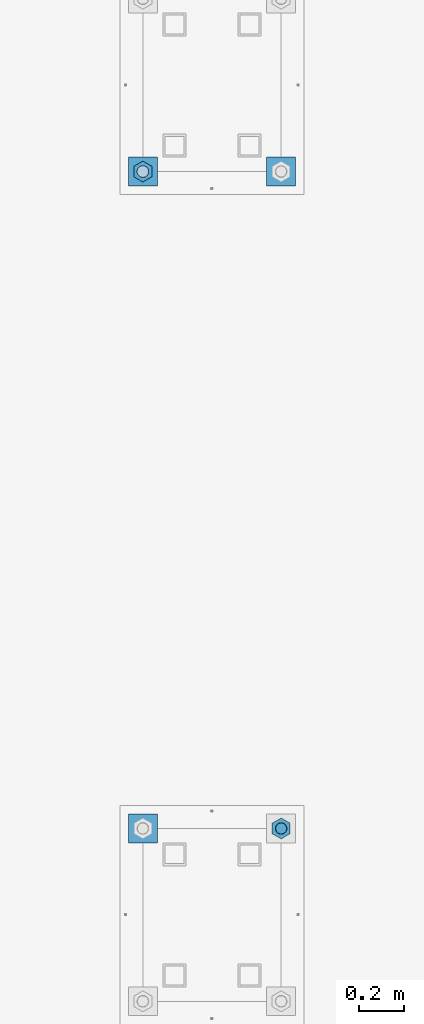
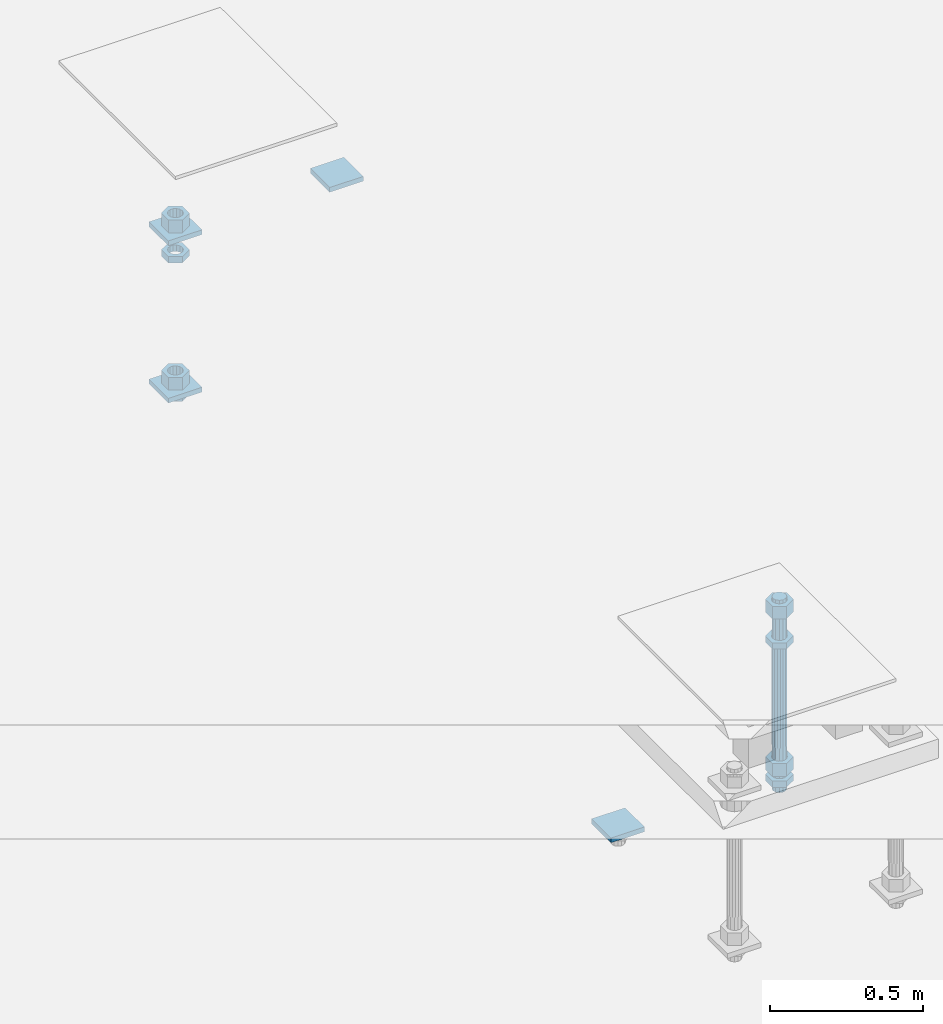
# One storey, part 2725 of 3843: 13 beams, 2 elements without a shape of their own.
"""IFC2X3 building model written with IfcOpenShell, lengths in millimetres."""

from ifc_helpers import new_model, si_unit, frame, origin_with_axes, place, context, subcontext, project, spatial, faceted_brep, material, type_object, element, aggregate, save


model = new_model("IFC2X3")

# Units and contexts
model_context = context("Model", 3, precision=1e-05, world=origin_with_axes())
body_context = subcontext(model_context, "Body", "Model", "MODEL_VIEW")
ifc_project = project(units=[si_unit("LENGTHUNIT", "METRE", prefix="MILLI"), si_unit("AREAUNIT", "SQUARE_METRE"), si_unit("VOLUMEUNIT", "CUBIC_METRE"), si_unit("MASSUNIT", "GRAM", prefix="KILO"), si_unit("TIMEUNIT", "SECOND"), si_unit("PLANEANGLEUNIT", "RADIAN"), si_unit("SOLIDANGLEUNIT", "STERADIAN"), si_unit("THERMODYNAMICTEMPERATUREUNIT", "DEGREE_CELSIUS"), si_unit("LUMINOUSINTENSITYUNIT", "LUMEN")], contexts=[model_context])

# Site, building, storey
site_placement = place(None, origin_with_axes())
site = spatial("IfcSite", under=ifc_project, at=site_placement, CompositionType="ELEMENT")
building_placement = place(site_placement, origin_with_axes())
building = spatial("IfcBuilding", under=site, at=building_placement, Name="Undefined", CompositionType="ELEMENT")
storey_placement = place(building_placement, origin_with_axes())
storey = spatial("IfcBuildingStorey", under=building, at=storey_placement, Name="Undefined", CompositionType="ELEMENT", Elevation=0.0)

# Assembly, beams
assembly_1_placement = place(storey_placement, origin_with_axes())
assembly_1 = element("IfcElementAssembly", 1, at=assembly_1_placement, inside=storey, Name="TEMPLATE", AssemblyPlace="NOTDEFINED", PredefinedType="RIGID_FRAME")
ifc_material_1 = material(Name="STEEL/A36")
beam_type_1 = type_object("IfcBeamType", PredefinedType="NOTDEFINED")
beam_1_placement = place(assembly_1_placement, frame((115862.099998474, 35737.8, 29873.575), z_axis=(0.0, 1.0, 0.0), x_axis=(-1.0, 0.0, 0.0)))
beam_1 = element("IfcBeam", 2, at=beam_1_placement, type_object=beam_type_1, material=ifc_material_1, Name="WASHER_PLATE", context=body_context, shape_type="Brep", body=[
    faceted_brep([(0.0, 9.52500000000146, -63.5), (0.0, 9.52500000000146, 63.5), (127.0, 9.52500000000146, 63.5), (127.0, 9.52500000000146, -63.5), (0.0, -9.52500000000146, 63.5), (127.0, -9.52500000000146, 63.5), (0.0, -9.52500000000146, -63.5), (127.0, -9.52500000000146, -63.5)], [[[0, 1, 2, 3]], [[1, 4, 5, 2]], [[4, 6, 7, 5]], [[6, 0, 3, 7]], [[5, 7, 3, 2]], [[6, 4, 1, 0]]]),
])
beam_2_placement = place(assembly_1_placement, frame((116471.7, 35737.8, 29873.575), z_axis=(0.0, 1.0, 0.0), x_axis=(-1.0, 0.0, 0.0)))
beam_2 = element("IfcBeam", 3, at=beam_2_placement, type_object=beam_type_1, material=ifc_material_1, Name="WASHER_PLATE", context=body_context, shape_type="Brep", body=[
    faceted_brep([(0.0, 9.52500000000146, -63.5), (0.0, 9.52500000000146, 63.5), (127.0, 9.52500000000146, 63.5), (127.0, 9.52500000000146, -63.5), (0.0, -9.52500000000146, 63.5), (127.0, -9.52500000000146, 63.5), (0.0, -9.52500000000146, -63.5), (127.0, -9.52500000000146, -63.5)], [[[0, 1, 2, 3]], [[1, 4, 5, 2]], [[4, 6, 7, 5]], [[6, 0, 3, 7]], [[5, 7, 3, 2]], [[6, 4, 1, 0]]]),
])
beam_3_placement = place(assembly_1_placement, frame((115862.099998474, 35737.8, 29244.925), z_axis=(0.0, 1.0, 0.0), x_axis=(-1.0, 0.0, 0.0)))
beam_3 = element("IfcBeam", 4, at=beam_3_placement, type_object=beam_type_1, material=ifc_material_1, Name="WASHER_PLATE", context=body_context, shape_type="Brep", body=[
    faceted_brep([(0.0, 9.52500000000146, -63.5), (0.0, 9.52500000000146, 63.5), (127.0, 9.52500000000146, 63.5), (127.0, 9.52500000000146, -63.5), (0.0, -9.52500000000146, 63.5), (127.0, -9.52500000000146, 63.5), (0.0, -9.52500000000146, -63.5), (127.0, -9.52500000000146, -63.5)], [[[0, 1, 2, 3]], [[1, 4, 5, 2]], [[4, 6, 7, 5]], [[6, 0, 3, 7]], [[5, 7, 3, 2]], [[6, 4, 1, 0]]]),
])

# Assembly, beam
assembly_2_placement = place(storey_placement, origin_with_axes())
assembly_2 = element("IfcElementAssembly", 5, at=assembly_2_placement, inside=storey, Name="TEMPLATE", AssemblyPlace="NOTDEFINED", PredefinedType="RIGID_FRAME")
beam_4_placement = place(assembly_2_placement, frame((115862.099998474, 32842.2, 29244.925), z_axis=(0.0, 1.0, 0.0), x_axis=(-1.0, 0.0, 0.0)))
beam_4 = element("IfcBeam", 6, at=beam_4_placement, type_object=beam_type_1, material=ifc_material_1, Name="WASHER_PLATE", context=body_context, shape_type="Brep", body=[
    faceted_brep([(0.0, 9.52500000000146, -63.5), (0.0, 9.52500000000146, 63.5), (127.0, 9.52500000000146, 63.5), (127.0, 9.52500000000146, -63.5), (0.0, -9.52500000000146, 63.5), (127.0, -9.52500000000146, 63.5), (0.0, -9.52500000000146, -63.5), (127.0, -9.52500000000146, -63.5)], [[[0, 1, 2, 3]], [[1, 4, 5, 2]], [[4, 6, 7, 5]], [[6, 0, 3, 7]], [[5, 7, 3, 2]], [[6, 4, 1, 0]]]),
])

# Beam
beam_type_2 = type_object("IfcBeamType", Name="2_HALF_NUT", PredefinedType="NOTDEFINED")
beam_5_placement = place(assembly_1_placement, frame((115798.599998474, 35737.8, 29787.85), z_axis=(-1.0, 0.0, 0.0), x_axis=(0.0, 0.0, -1.0)))
beam_5 = element("IfcBeam", 7, at=beam_5_placement, type_object=beam_type_2, material=ifc_material_1, Name="NUT", ObjectType="2_HALF_NUT", context=body_context, shape_type="Brep", body=[
    faceted_brep([(0.0, -46.0369987487793, 0.0), (0.0, -23.0184993743896, -39.869213104248), (25.4000000000015, -23.0184993743896, -39.869213104248), (25.4000000000015, -46.0369987487793, 0.0), (0.0, 23.0184993743896, -39.869213104248), (25.4000000000015, 23.0184993743896, -39.869213104248), (0.0, 46.0369987487793, 0.0), (25.4000000000015, 46.0369987487793, 0.0), (0.0, 23.0184993743896, 39.869213104248), (25.4000000000015, 23.0184993743896, 39.869213104248), (0.0, -23.0184993743896, 39.869213104248), (25.4000000000015, -23.0184993743896, 39.869213104248), (0.0, 0.0, 26.1940002441406), (0.0, 11.3650617044477, 23.5999013092805), (25.4000000000015, 11.3650617044477, 23.5999013092805), (25.4000000000015, 0.0, 26.1940002441406), (0.0, 20.4791109456419, 16.3316083006721), (25.4000000000015, 20.4791109456419, 16.3316083006721), (0.0, 25.5370200498292, 5.82867859874386), (25.4000000000015, 25.5370200498292, 5.82867859874386), (0.0, 25.5370200498292, -5.82867859874386), (25.4000000000015, 25.5370200498292, -5.82867859874386), (0.0, 20.4791109456419, -16.3316083006721), (25.4000000000015, 20.4791109456419, -16.3316083006721), (0.0, 11.3650617044477, -23.5999013092805), (25.4000000000015, 11.3650617044477, -23.5999013092805), (0.0, 0.0, -26.1940002441406), (25.4000000000015, 0.0, -26.1940002441406), (0.0, -11.3650617044477, -23.5999013092805), (25.4000000000015, -11.3650617044477, -23.5999013092805), (0.0, -20.4791109456419, -16.3316083006721), (25.4000000000015, -20.4791109456419, -16.3316083006721), (0.0, -25.5370200498292, -5.82867859874386), (25.4000000000015, -25.5370200498292, -5.82867859874386), (0.0, -25.5370200498292, 5.82867859874386), (25.4000000000015, -25.5370200498292, 5.82867859874386), (0.0, -20.4791109456419, 16.3316083006721), (25.4000000000015, -20.4791109456419, 16.3316083006721), (0.0, -11.3650617044477, 23.5999013092805), (25.4000000000015, -11.3650617044477, 23.5999013092805)], [[[0, 1, 2, 3]], [[1, 4, 5, 2]], [[4, 6, 7, 5]], [[6, 8, 9, 7]], [[8, 10, 11, 9]], [[10, 0, 3, 11]], [[12, 13, 14, 15]], [[13, 16, 17, 14]], [[16, 18, 19, 17]], [[18, 20, 21, 19]], [[20, 22, 23, 21]], [[22, 24, 25, 23]], [[24, 26, 27, 25]], [[26, 28, 29, 27]], [[28, 30, 31, 29]], [[30, 32, 33, 31]], [[32, 34, 35, 33]], [[34, 36, 37, 35]], [[36, 38, 39, 37]], [[38, 12, 15, 39]], [[5, 7, 9, 11, 3, 2], [17, 19, 21, 23, 25, 27, 29, 31, 33, 35, 37, 39, 15, 14]], [[10, 8, 6, 4, 1, 0], [38, 36, 34, 32, 30, 28, 26, 24, 22, 20, 18, 16, 13, 12]]]),
])

beam_6_placement = place(assembly_1_placement, frame((115798.599998474, 35737.8, 29235.4), z_axis=(-1.0, 0.0, 0.0), x_axis=(0.0, 0.0, -1.0)))
beam_6 = element("IfcBeam", 8, at=beam_6_placement, type_object=beam_type_2, material=ifc_material_1, Name="NUT", ObjectType="2_HALF_NUT", context=body_context, shape_type="Brep", body=[
    faceted_brep([(0.0, -46.0369987487793, 0.0), (0.0, -23.0184993743896, -39.869213104248), (25.4000000000015, -23.0184993743896, -39.869213104248), (25.4000000000015, -46.0369987487793, 0.0), (0.0, 23.0184993743896, -39.869213104248), (25.4000000000015, 23.0184993743896, -39.869213104248), (0.0, 46.0369987487793, 0.0), (25.4000000000015, 46.0369987487793, 0.0), (0.0, 23.0184993743896, 39.869213104248), (25.4000000000015, 23.0184993743896, 39.869213104248), (0.0, -23.0184993743896, 39.869213104248), (25.4000000000015, -23.0184993743896, 39.869213104248), (0.0, 0.0, 26.1940002441406), (0.0, 11.3650617044477, 23.5999013092805), (25.4000000000015, 11.3650617044477, 23.5999013092805), (25.4000000000015, 0.0, 26.1940002441406), (0.0, 20.4791109456419, 16.3316083006721), (25.4000000000015, 20.4791109456419, 16.3316083006721), (0.0, 25.5370200498292, 5.82867859874386), (25.4000000000015, 25.5370200498292, 5.82867859874386), (0.0, 25.5370200498292, -5.82867859874386), (25.4000000000015, 25.5370200498292, -5.82867859874386), (0.0, 20.4791109456419, -16.3316083006721), (25.4000000000015, 20.4791109456419, -16.3316083006721), (0.0, 11.3650617044477, -23.5999013092805), (25.4000000000015, 11.3650617044477, -23.5999013092805), (0.0, 0.0, -26.1940002441406), (25.4000000000015, 0.0, -26.1940002441406), (0.0, -11.3650617044477, -23.5999013092805), (25.4000000000015, -11.3650617044477, -23.5999013092805), (0.0, -20.4791109456419, -16.3316083006721), (25.4000000000015, -20.4791109456419, -16.3316083006721), (0.0, -25.5370200498292, -5.82867859874386), (25.4000000000015, -25.5370200498292, -5.82867859874386), (0.0, -25.5370200498292, 5.82867859874386), (25.4000000000015, -25.5370200498292, 5.82867859874386), (0.0, -20.4791109456419, 16.3316083006721), (25.4000000000015, -20.4791109456419, 16.3316083006721), (0.0, -11.3650617044477, 23.5999013092805), (25.4000000000015, -11.3650617044477, 23.5999013092805)], [[[0, 1, 2, 3]], [[1, 4, 5, 2]], [[4, 6, 7, 5]], [[6, 8, 9, 7]], [[8, 10, 11, 9]], [[10, 0, 3, 11]], [[12, 13, 14, 15]], [[13, 16, 17, 14]], [[16, 18, 19, 17]], [[18, 20, 21, 19]], [[20, 22, 23, 21]], [[22, 24, 25, 23]], [[24, 26, 27, 25]], [[26, 28, 29, 27]], [[28, 30, 31, 29]], [[30, 32, 33, 31]], [[32, 34, 35, 33]], [[34, 36, 37, 35]], [[36, 38, 39, 37]], [[38, 12, 15, 39]], [[5, 7, 9, 11, 3, 2], [17, 19, 21, 23, 25, 27, 29, 31, 33, 35, 37, 39, 15, 14]], [[10, 8, 6, 4, 1, 0], [38, 36, 34, 32, 30, 28, 26, 24, 22, 20, 18, 16, 13, 12]]]),
])

beam_7_placement = place(assembly_2_placement, frame((116408.2, 32842.2, 29787.85), z_axis=(-1.0, 0.0, 0.0), x_axis=(0.0, 0.0, -1.0)))
beam_7 = element("IfcBeam", 9, at=beam_7_placement, type_object=beam_type_2, material=ifc_material_1, Name="NUT", ObjectType="2_HALF_NUT", context=body_context, shape_type="Brep", body=[
    faceted_brep([(0.0, -46.0369987487793, 0.0), (0.0, -23.0184993743896, -39.869213104248), (25.4000000000015, -23.0184993743896, -39.869213104248), (25.4000000000015, -46.0369987487793, 0.0), (0.0, 23.0184993743896, -39.869213104248), (25.4000000000015, 23.0184993743896, -39.869213104248), (0.0, 46.0369987487793, 0.0), (25.4000000000015, 46.0369987487793, 0.0), (0.0, 23.0184993743896, 39.869213104248), (25.4000000000015, 23.0184993743896, 39.869213104248), (0.0, -23.0184993743896, 39.869213104248), (25.4000000000015, -23.0184993743896, 39.869213104248), (0.0, 0.0, 26.1940002441406), (0.0, 11.3650617044477, 23.5999013092805), (25.4000000000015, 11.3650617044477, 23.5999013092805), (25.4000000000015, 0.0, 26.1940002441406), (0.0, 20.4791109456419, 16.3316083006721), (25.4000000000015, 20.4791109456419, 16.3316083006721), (0.0, 25.5370200498292, 5.82867859874386), (25.4000000000015, 25.5370200498292, 5.82867859874386), (0.0, 25.5370200498292, -5.82867859874386), (25.4000000000015, 25.5370200498292, -5.82867859874386), (0.0, 20.4791109456419, -16.3316083006721), (25.4000000000015, 20.4791109456419, -16.3316083006721), (0.0, 11.3650617044477, -23.5999013092805), (25.4000000000015, 11.3650617044477, -23.5999013092805), (0.0, 0.0, -26.1940002441406), (25.4000000000015, 0.0, -26.1940002441406), (0.0, -11.3650617044477, -23.5999013092805), (25.4000000000015, -11.3650617044477, -23.5999013092805), (0.0, -20.4791109456419, -16.3316083006721), (25.4000000000015, -20.4791109456419, -16.3316083006721), (0.0, -25.5370200498292, -5.82867859874386), (25.4000000000015, -25.5370200498292, -5.82867859874386), (0.0, -25.5370200498292, 5.82867859874386), (25.4000000000015, -25.5370200498292, 5.82867859874386), (0.0, -20.4791109456419, 16.3316083006721), (25.4000000000015, -20.4791109456419, 16.3316083006721), (0.0, -11.3650617044477, 23.5999013092805), (25.4000000000015, -11.3650617044477, 23.5999013092805)], [[[0, 1, 2, 3]], [[1, 4, 5, 2]], [[4, 6, 7, 5]], [[6, 8, 9, 7]], [[8, 10, 11, 9]], [[10, 0, 3, 11]], [[12, 13, 14, 15]], [[13, 16, 17, 14]], [[16, 18, 19, 17]], [[18, 20, 21, 19]], [[20, 22, 23, 21]], [[22, 24, 25, 23]], [[24, 26, 27, 25]], [[26, 28, 29, 27]], [[28, 30, 31, 29]], [[30, 32, 33, 31]], [[32, 34, 35, 33]], [[34, 36, 37, 35]], [[36, 38, 39, 37]], [[38, 12, 15, 39]], [[5, 7, 9, 11, 3, 2], [17, 19, 21, 23, 25, 27, 29, 31, 33, 35, 37, 39, 15, 14]], [[10, 8, 6, 4, 1, 0], [38, 36, 34, 32, 30, 28, 26, 24, 22, 20, 18, 16, 13, 12]]]),
])

beam_8_placement = place(assembly_2_placement, frame((116408.2, 32842.2, 29235.4), z_axis=(-1.0, 0.0, 0.0), x_axis=(0.0, 0.0, -1.0)))
beam_8 = element("IfcBeam", 10, at=beam_8_placement, type_object=beam_type_2, material=ifc_material_1, Name="NUT", ObjectType="2_HALF_NUT", context=body_context, shape_type="Brep", body=[
    faceted_brep([(0.0, -46.0369987487793, 0.0), (0.0, -23.0184993743896, -39.869213104248), (25.4000000000015, -23.0184993743896, -39.869213104248), (25.4000000000015, -46.0369987487793, 0.0), (0.0, 23.0184993743896, -39.869213104248), (25.4000000000015, 23.0184993743896, -39.869213104248), (0.0, 46.0369987487793, 0.0), (25.4000000000015, 46.0369987487793, 0.0), (0.0, 23.0184993743896, 39.869213104248), (25.4000000000015, 23.0184993743896, 39.869213104248), (0.0, -23.0184993743896, 39.869213104248), (25.4000000000015, -23.0184993743896, 39.869213104248), (0.0, 0.0, 26.1940002441406), (0.0, 11.3650617044477, 23.5999013092805), (25.4000000000015, 11.3650617044477, 23.5999013092805), (25.4000000000015, 0.0, 26.1940002441406), (0.0, 20.4791109456419, 16.3316083006721), (25.4000000000015, 20.4791109456419, 16.3316083006721), (0.0, 25.5370200498292, 5.82867859874386), (25.4000000000015, 25.5370200498292, 5.82867859874386), (0.0, 25.5370200498292, -5.82867859874386), (25.4000000000015, 25.5370200498292, -5.82867859874386), (0.0, 20.4791109456419, -16.3316083006721), (25.4000000000015, 20.4791109456419, -16.3316083006721), (0.0, 11.3650617044477, -23.5999013092805), (25.4000000000015, 11.3650617044477, -23.5999013092805), (0.0, 0.0, -26.1940002441406), (25.4000000000015, 0.0, -26.1940002441406), (0.0, -11.3650617044477, -23.5999013092805), (25.4000000000015, -11.3650617044477, -23.5999013092805), (0.0, -20.4791109456419, -16.3316083006721), (25.4000000000015, -20.4791109456419, -16.3316083006721), (0.0, -25.5370200498292, -5.82867859874386), (25.4000000000015, -25.5370200498292, -5.82867859874386), (0.0, -25.5370200498292, 5.82867859874386), (25.4000000000015, -25.5370200498292, 5.82867859874386), (0.0, -20.4791109456419, 16.3316083006721), (25.4000000000015, -20.4791109456419, 16.3316083006721), (0.0, -11.3650617044477, 23.5999013092805), (25.4000000000015, -11.3650617044477, 23.5999013092805)], [[[0, 1, 2, 3]], [[1, 4, 5, 2]], [[4, 6, 7, 5]], [[6, 8, 9, 7]], [[8, 10, 11, 9]], [[10, 0, 3, 11]], [[12, 13, 14, 15]], [[13, 16, 17, 14]], [[16, 18, 19, 17]], [[18, 20, 21, 19]], [[20, 22, 23, 21]], [[22, 24, 25, 23]], [[24, 26, 27, 25]], [[26, 28, 29, 27]], [[28, 30, 31, 29]], [[30, 32, 33, 31]], [[32, 34, 35, 33]], [[34, 36, 37, 35]], [[36, 38, 39, 37]], [[38, 12, 15, 39]], [[5, 7, 9, 11, 3, 2], [17, 19, 21, 23, 25, 27, 29, 31, 33, 35, 37, 39, 15, 14]], [[10, 8, 6, 4, 1, 0], [38, 36, 34, 32, 30, 28, 26, 24, 22, 20, 18, 16, 13, 12]]]),
])

beam_type_3 = type_object("IfcBeamType", Name="2_HEAVY_HEX_NUT", PredefinedType="NOTDEFINED")
beam_9_placement = place(assembly_1_placement, frame((115798.599998474, 35737.8, 29933.9), z_axis=(-1.0, 0.0, 0.0), x_axis=(0.0, 0.0, -1.0)))
beam_9 = element("IfcBeam", 11, at=beam_9_placement, type_object=beam_type_3, material=ifc_material_1, Name="NUT", ObjectType="2_HEAVY_HEX_NUT", context=body_context, shape_type="Brep", body=[
    faceted_brep([(0.0, -46.0369987487793, 0.0), (0.0, -23.0184993743896, -39.869213104248), (50.7999999999993, -23.0184993743896, -39.869213104248), (50.7999999999993, -46.0369987487793, 0.0), (0.0, 23.0184993743896, -39.869213104248), (50.7999999999993, 23.0184993743896, -39.869213104248), (0.0, 46.0369987487793, 0.0), (50.7999999999993, 46.0369987487793, 0.0), (0.0, 23.0184993743896, 39.869213104248), (50.7999999999993, 23.0184993743896, 39.869213104248), (0.0, -23.0184993743896, 39.869213104248), (50.7999999999993, -23.0184993743896, 39.869213104248), (0.0, 0.0, 26.1940002441406), (0.0, 11.3650617044477, 23.5999013092805), (50.7999999999993, 11.3650617044477, 23.5999013092805), (50.7999999999993, 0.0, 26.1940002441406), (0.0, 20.4791109456419, 16.3316083006721), (50.7999999999993, 20.4791109456419, 16.3316083006721), (0.0, 25.5370200498292, 5.82867859874386), (50.7999999999993, 25.5370200498292, 5.82867859874386), (0.0, 25.5370200498292, -5.82867859874386), (50.7999999999993, 25.5370200498292, -5.82867859874386), (0.0, 20.4791109456419, -16.3316083006721), (50.7999999999993, 20.4791109456419, -16.3316083006721), (0.0, 11.3650617044477, -23.5999013092805), (50.7999999999993, 11.3650617044477, -23.5999013092805), (0.0, 0.0, -26.1940002441406), (50.7999999999993, 0.0, -26.1940002441406), (0.0, -11.3650617044477, -23.5999013092805), (50.7999999999993, -11.3650617044477, -23.5999013092805), (0.0, -20.4791109456419, -16.3316083006721), (50.7999999999993, -20.4791109456419, -16.3316083006721), (0.0, -25.5370200498292, -5.82867859874386), (50.7999999999993, -25.5370200498292, -5.82867859874386), (0.0, -25.5370200498292, 5.82867859874386), (50.7999999999993, -25.5370200498292, 5.82867859874386), (0.0, -20.4791109456419, 16.3316083006721), (50.7999999999993, -20.4791109456419, 16.3316083006721), (0.0, -11.3650617044477, 23.5999013092805), (50.7999999999993, -11.3650617044477, 23.5999013092805)], [[[0, 1, 2, 3]], [[1, 4, 5, 2]], [[4, 6, 7, 5]], [[6, 8, 9, 7]], [[8, 10, 11, 9]], [[10, 0, 3, 11]], [[12, 13, 14, 15]], [[13, 16, 17, 14]], [[16, 18, 19, 17]], [[18, 20, 21, 19]], [[20, 22, 23, 21]], [[22, 24, 25, 23]], [[24, 26, 27, 25]], [[26, 28, 29, 27]], [[28, 30, 31, 29]], [[30, 32, 33, 31]], [[32, 34, 35, 33]], [[34, 36, 37, 35]], [[36, 38, 39, 37]], [[38, 12, 15, 39]], [[5, 7, 9, 11, 3, 2], [17, 19, 21, 23, 25, 27, 29, 31, 33, 35, 37, 39, 15, 14]], [[10, 8, 6, 4, 1, 0], [38, 36, 34, 32, 30, 28, 26, 24, 22, 20, 18, 16, 13, 12]]]),
])

beam_10_placement = place(assembly_1_placement, frame((115798.599998474, 35737.8, 29305.25), z_axis=(-1.0, 0.0, 0.0), x_axis=(0.0, 0.0, -1.0)))
beam_10 = element("IfcBeam", 12, at=beam_10_placement, type_object=beam_type_3, material=ifc_material_1, Name="NUT", ObjectType="2_HEAVY_HEX_NUT", context=body_context, shape_type="Brep", body=[
    faceted_brep([(0.0, -46.0369987487793, 0.0), (0.0, -23.0184993743896, -39.869213104248), (50.7999999999993, -23.0184993743896, -39.869213104248), (50.7999999999993, -46.0369987487793, 0.0), (0.0, 23.0184993743896, -39.869213104248), (50.7999999999993, 23.0184993743896, -39.869213104248), (0.0, 46.0369987487793, 0.0), (50.7999999999993, 46.0369987487793, 0.0), (0.0, 23.0184993743896, 39.869213104248), (50.7999999999993, 23.0184993743896, 39.869213104248), (0.0, -23.0184993743896, 39.869213104248), (50.7999999999993, -23.0184993743896, 39.869213104248), (0.0, 0.0, 26.1940002441406), (0.0, 11.3650617044477, 23.5999013092805), (50.7999999999993, 11.3650617044477, 23.5999013092805), (50.7999999999993, 0.0, 26.1940002441406), (0.0, 20.4791109456419, 16.3316083006721), (50.7999999999993, 20.4791109456419, 16.3316083006721), (0.0, 25.5370200498292, 5.82867859874386), (50.7999999999993, 25.5370200498292, 5.82867859874386), (0.0, 25.5370200498292, -5.82867859874386), (50.7999999999993, 25.5370200498292, -5.82867859874386), (0.0, 20.4791109456419, -16.3316083006721), (50.7999999999993, 20.4791109456419, -16.3316083006721), (0.0, 11.3650617044477, -23.5999013092805), (50.7999999999993, 11.3650617044477, -23.5999013092805), (0.0, 0.0, -26.1940002441406), (50.7999999999993, 0.0, -26.1940002441406), (0.0, -11.3650617044477, -23.5999013092805), (50.7999999999993, -11.3650617044477, -23.5999013092805), (0.0, -20.4791109456419, -16.3316083006721), (50.7999999999993, -20.4791109456419, -16.3316083006721), (0.0, -25.5370200498292, -5.82867859874386), (50.7999999999993, -25.5370200498292, -5.82867859874386), (0.0, -25.5370200498292, 5.82867859874386), (50.7999999999993, -25.5370200498292, 5.82867859874386), (0.0, -20.4791109456419, 16.3316083006721), (50.7999999999993, -20.4791109456419, 16.3316083006721), (0.0, -11.3650617044477, 23.5999013092805), (50.7999999999993, -11.3650617044477, 23.5999013092805)], [[[0, 1, 2, 3]], [[1, 4, 5, 2]], [[4, 6, 7, 5]], [[6, 8, 9, 7]], [[8, 10, 11, 9]], [[10, 0, 3, 11]], [[12, 13, 14, 15]], [[13, 16, 17, 14]], [[16, 18, 19, 17]], [[18, 20, 21, 19]], [[20, 22, 23, 21]], [[22, 24, 25, 23]], [[24, 26, 27, 25]], [[26, 28, 29, 27]], [[28, 30, 31, 29]], [[30, 32, 33, 31]], [[32, 34, 35, 33]], [[34, 36, 37, 35]], [[36, 38, 39, 37]], [[38, 12, 15, 39]], [[5, 7, 9, 11, 3, 2], [17, 19, 21, 23, 25, 27, 29, 31, 33, 35, 37, 39, 15, 14]], [[10, 8, 6, 4, 1, 0], [38, 36, 34, 32, 30, 28, 26, 24, 22, 20, 18, 16, 13, 12]]]),
])

aggregate(assembly_1, [beam_1, beam_2, beam_3, beam_5, beam_9, beam_10, beam_6])

beam_11_placement = place(assembly_2_placement, frame((116408.2, 32842.2, 29933.9), z_axis=(-1.0, 0.0, 0.0), x_axis=(0.0, 0.0, -1.0)))
beam_11 = element("IfcBeam", 13, at=beam_11_placement, type_object=beam_type_3, material=ifc_material_1, Name="NUT", ObjectType="2_HEAVY_HEX_NUT", context=body_context, shape_type="Brep", body=[
    faceted_brep([(0.0, -46.0369987487793, 0.0), (0.0, -23.0184993743896, -39.869213104248), (50.7999999999993, -23.0184993743896, -39.869213104248), (50.7999999999993, -46.0369987487793, 0.0), (0.0, 23.0184993743896, -39.869213104248), (50.7999999999993, 23.0184993743896, -39.869213104248), (0.0, 46.0369987487793, 0.0), (50.7999999999993, 46.0369987487793, 0.0), (0.0, 23.0184993743896, 39.869213104248), (50.7999999999993, 23.0184993743896, 39.869213104248), (0.0, -23.0184993743896, 39.869213104248), (50.7999999999993, -23.0184993743896, 39.869213104248), (0.0, 0.0, 26.1940002441406), (0.0, 11.3650617044477, 23.5999013092805), (50.7999999999993, 11.3650617044477, 23.5999013092805), (50.7999999999993, 0.0, 26.1940002441406), (0.0, 20.4791109456419, 16.3316083006721), (50.7999999999993, 20.4791109456419, 16.3316083006721), (0.0, 25.5370200498292, 5.82867859874386), (50.7999999999993, 25.5370200498292, 5.82867859874386), (0.0, 25.5370200498292, -5.82867859874386), (50.7999999999993, 25.5370200498292, -5.82867859874386), (0.0, 20.4791109456419, -16.3316083006721), (50.7999999999993, 20.4791109456419, -16.3316083006721), (0.0, 11.3650617044477, -23.5999013092805), (50.7999999999993, 11.3650617044477, -23.5999013092805), (0.0, 0.0, -26.1940002441406), (50.7999999999993, 0.0, -26.1940002441406), (0.0, -11.3650617044477, -23.5999013092805), (50.7999999999993, -11.3650617044477, -23.5999013092805), (0.0, -20.4791109456419, -16.3316083006721), (50.7999999999993, -20.4791109456419, -16.3316083006721), (0.0, -25.5370200498292, -5.82867859874386), (50.7999999999993, -25.5370200498292, -5.82867859874386), (0.0, -25.5370200498292, 5.82867859874386), (50.7999999999993, -25.5370200498292, 5.82867859874386), (0.0, -20.4791109456419, 16.3316083006721), (50.7999999999993, -20.4791109456419, 16.3316083006721), (0.0, -11.3650617044477, 23.5999013092805), (50.7999999999993, -11.3650617044477, 23.5999013092805)], [[[0, 1, 2, 3]], [[1, 4, 5, 2]], [[4, 6, 7, 5]], [[6, 8, 9, 7]], [[8, 10, 11, 9]], [[10, 0, 3, 11]], [[12, 13, 14, 15]], [[13, 16, 17, 14]], [[16, 18, 19, 17]], [[18, 20, 21, 19]], [[20, 22, 23, 21]], [[22, 24, 25, 23]], [[24, 26, 27, 25]], [[26, 28, 29, 27]], [[28, 30, 31, 29]], [[30, 32, 33, 31]], [[32, 34, 35, 33]], [[34, 36, 37, 35]], [[36, 38, 39, 37]], [[38, 12, 15, 39]], [[5, 7, 9, 11, 3, 2], [17, 19, 21, 23, 25, 27, 29, 31, 33, 35, 37, 39, 15, 14]], [[10, 8, 6, 4, 1, 0], [38, 36, 34, 32, 30, 28, 26, 24, 22, 20, 18, 16, 13, 12]]]),
])

beam_12_placement = place(assembly_2_placement, frame((116408.2, 32842.2, 29305.25), z_axis=(-1.0, 0.0, 0.0), x_axis=(0.0, 0.0, -1.0)))
beam_12 = element("IfcBeam", 14, at=beam_12_placement, type_object=beam_type_3, material=ifc_material_1, Name="NUT", ObjectType="2_HEAVY_HEX_NUT", context=body_context, shape_type="Brep", body=[
    faceted_brep([(0.0, -46.0369987487793, 0.0), (0.0, -23.0184993743896, -39.869213104248), (50.7999999999993, -23.0184993743896, -39.869213104248), (50.7999999999993, -46.0369987487793, 0.0), (0.0, 23.0184993743896, -39.869213104248), (50.7999999999993, 23.0184993743896, -39.869213104248), (0.0, 46.0369987487793, 0.0), (50.7999999999993, 46.0369987487793, 0.0), (0.0, 23.0184993743896, 39.869213104248), (50.7999999999993, 23.0184993743896, 39.869213104248), (0.0, -23.0184993743896, 39.869213104248), (50.7999999999993, -23.0184993743896, 39.869213104248), (0.0, 0.0, 26.1940002441406), (0.0, 11.3650617044477, 23.5999013092805), (50.7999999999993, 11.3650617044477, 23.5999013092805), (50.7999999999993, 0.0, 26.1940002441406), (0.0, 20.4791109456419, 16.3316083006721), (50.7999999999993, 20.4791109456419, 16.3316083006721), (0.0, 25.5370200498292, 5.82867859874386), (50.7999999999993, 25.5370200498292, 5.82867859874386), (0.0, 25.5370200498292, -5.82867859874386), (50.7999999999993, 25.5370200498292, -5.82867859874386), (0.0, 20.4791109456419, -16.3316083006721), (50.7999999999993, 20.4791109456419, -16.3316083006721), (0.0, 11.3650617044477, -23.5999013092805), (50.7999999999993, 11.3650617044477, -23.5999013092805), (0.0, 0.0, -26.1940002441406), (50.7999999999993, 0.0, -26.1940002441406), (0.0, -11.3650617044477, -23.5999013092805), (50.7999999999993, -11.3650617044477, -23.5999013092805), (0.0, -20.4791109456419, -16.3316083006721), (50.7999999999993, -20.4791109456419, -16.3316083006721), (0.0, -25.5370200498292, -5.82867859874386), (50.7999999999993, -25.5370200498292, -5.82867859874386), (0.0, -25.5370200498292, 5.82867859874386), (50.7999999999993, -25.5370200498292, 5.82867859874386), (0.0, -20.4791109456419, 16.3316083006721), (50.7999999999993, -20.4791109456419, 16.3316083006721), (0.0, -11.3650617044477, 23.5999013092805), (50.7999999999993, -11.3650617044477, 23.5999013092805)], [[[0, 1, 2, 3]], [[1, 4, 5, 2]], [[4, 6, 7, 5]], [[6, 8, 9, 7]], [[8, 10, 11, 9]], [[10, 0, 3, 11]], [[12, 13, 14, 15]], [[13, 16, 17, 14]], [[16, 18, 19, 17]], [[18, 20, 21, 19]], [[20, 22, 23, 21]], [[22, 24, 25, 23]], [[24, 26, 27, 25]], [[26, 28, 29, 27]], [[28, 30, 31, 29]], [[30, 32, 33, 31]], [[32, 34, 35, 33]], [[34, 36, 37, 35]], [[36, 38, 39, 37]], [[38, 12, 15, 39]], [[5, 7, 9, 11, 3, 2], [17, 19, 21, 23, 25, 27, 29, 31, 33, 35, 37, 39, 15, 14]], [[10, 8, 6, 4, 1, 0], [38, 36, 34, 32, 30, 28, 26, 24, 22, 20, 18, 16, 13, 12]]]),
])

ifc_material_2 = material()
beam_type_4 = type_object("IfcBeamType", PredefinedType="NOTDEFINED")
beam_13_placement = place(assembly_2_placement, frame((116408.2, 32842.2, 29762.45), z_axis=(-1.0, 0.0, 0.0), x_axis=(0.0, 0.0, -1.0)))
beam_13 = element("IfcBeam", 15, at=beam_13_placement, type_object=beam_type_4, material=ifc_material_2, Name="ANCHOR_ROD", context=body_context, shape_type="Brep", body=[
    faceted_brep([(-184.150000000001, -21.217622392709, 12.25), (-184.150000000001, -12.2499999999854, 21.2176223927163), (-184.150000000001, 1.45519152283669e-11, 24.5), (-184.150000000001, 12.2500000000146, 21.2176223927163), (-184.150000000001, 21.2176223927381, 12.25), (-184.150000000001, 24.5000000000146, 0.0), (-184.150000000001, 21.2176223927381, -12.25), (-184.150000000001, 12.2500000000146, -21.2176223927163), (-184.150000000001, 1.45519152283669e-11, -24.5), (-184.150000000001, -12.2499999999854, -21.2176223927163), (-184.150000000001, -21.217622392709, -12.25), (-184.150000000001, -24.4999999999854, 0.0), (0.0, 24.5000000000146, 0.0), (0.0, 21.2176223927381, -12.25), (0.0, 12.2500000000146, -21.2176223927163), (0.0, 1.45519152283669e-11, -24.5), (0.0, -12.2499999999854, -21.2176223927163), (0.0, -21.217622392709, -12.25), (0.0, -24.4999999999854, 0.0), (0.0, -21.217622392709, 12.25), (0.0, -12.2499999999854, 21.2176223927163), (0.0, 1.45519152283669e-11, 24.5), (0.0, 12.2500000000146, 21.2176223927163), (0.0, 21.2176223927381, 12.25), (0.0, -23.4665401257807, 9.72015918207035), (0.0, -17.9605122421344, 17.9605122421417), (0.0, -9.72015918207762, 23.466540125788), (0.0, 0.0, 25.4000000000015), (0.0, 9.72015918207762, 23.466540125788), (0.0, 17.9605122421344, 17.9605122421417), (0.0, 23.4665401257807, 9.72015918207035), (0.0, 25.3999996185303, 0.0), (0.0, 23.4665401257807, -9.72015918207035), (0.0, 17.9605122421344, -17.9605122421417), (0.0, 9.72015918207762, -23.466540125788), (0.0, 0.0, -25.4000000000015), (0.0, -9.72015918207762, -23.466540125788), (0.0, -17.9605122421344, -17.9605122421417), (0.0, -23.4665401257807, -9.72015918207035), (0.0, -25.3999996185303, 0.0), (406.399999999998, -25.3999999999942, 0.0), (406.399999999998, -23.4665401257807, 9.72015918207035), (406.399999999998, -17.9605122421344, 17.9605122421417), (406.399999999998, -9.72015918207762, 23.466540125788), (406.399999999998, 0.0, 25.4000000000015), (406.399999999998, 9.72015918207762, 23.466540125788), (406.399999999998, 17.9605122421344, 17.9605122421417), (406.399999999998, 23.4665401257807, 9.72015918207035), (406.399999999998, 25.3999999999942, 0.0), (406.399999999998, 23.4665401257807, -9.72015918207035), (406.399999999998, 17.9605122421344, -17.9605122421417), (406.399999999998, 9.72015918207762, -23.466540125788), (406.399999999998, 0.0, -25.4000000000015), (406.399999999998, -9.72015918207762, -23.466540125788), (406.399999999998, -17.9605122421344, -17.9605122421417), (406.399999999998, -23.4665401257807, -9.72015918207035), (406.399999999998, -12.2499999999854, 21.2176223927163), (406.399999999998, 1.45519152283669e-11, 24.5), (406.399999999998, 12.2500000000146, 21.2176223927163), (406.399999999998, 21.2176223927381, 12.25), (406.399999999998, 24.5000000000146, 0.0), (406.399999999998, 21.2176223927381, -12.25), (406.399999999998, 12.2500000000146, -21.2176223927163), (406.399999999998, 1.45519152283669e-11, -24.5), (406.399999999998, -12.2499999999854, -21.2176223927163), (406.399999999998, -21.217622392709, -12.25), (406.399999999998, -24.4999999999854, 0.0), (406.399999999998, -21.217622392709, 12.25), (584.200000000001, -12.2499999999854, -21.2176223927163), (584.200000000001, 1.45519152283669e-11, -24.5), (584.200000000001, 12.2500000000146, -21.2176223927163), (584.200000000001, 21.2176223927381, -12.25), (584.200000000001, 24.5000000000146, 0.0), (584.200000000001, 21.2176223927381, 12.25), (584.200000000001, 12.2500000000146, 21.2176223927163), (584.200000000001, 1.45519152283669e-11, 24.5), (584.200000000001, -12.2499999999854, 21.2176223927163), (584.200000000001, -21.217622392709, 12.25), (584.200000000001, -24.4999999999854, 0.0), (584.200000000001, -21.217622392709, -12.25)], [[[0, 1, 2, 3, 4, 5, 6, 7, 8, 9, 10, 11]], [[6, 5, 12, 13]], [[7, 6, 13, 14]], [[8, 7, 14, 15]], [[9, 8, 15, 16]], [[10, 9, 16, 17]], [[11, 10, 17, 18]], [[0, 11, 18, 19]], [[1, 0, 19, 20]], [[2, 1, 20, 21]], [[3, 2, 21, 22]], [[4, 3, 22, 23]], [[5, 4, 23, 12]], [[24, 25, 26, 27, 28, 29, 30, 31, 32, 33, 34, 35, 36, 37, 38, 39], [22, 21, 20, 19, 18, 17, 16, 15, 14, 13, 12, 23]], [[24, 39, 40, 41]], [[25, 24, 41, 42]], [[26, 25, 42, 43]], [[27, 26, 43, 44]], [[28, 27, 44, 45]], [[29, 28, 45, 46]], [[30, 29, 46, 47]], [[31, 30, 47, 48]], [[32, 31, 48, 49]], [[33, 32, 49, 50]], [[34, 33, 50, 51]], [[35, 34, 51, 52]], [[36, 35, 52, 53]], [[37, 36, 53, 54]], [[38, 37, 54, 55]], [[39, 38, 55, 40]], [[54, 53, 52, 51, 50, 49, 48, 47, 46, 45, 44, 43, 42, 41, 40, 55], [56, 57, 58, 59, 60, 61, 62, 63, 64, 65, 66, 67]], [[68, 69, 70, 71, 72, 73, 74, 75, 76, 77, 78, 79]], [[76, 75, 57, 56]], [[77, 76, 56, 67]], [[78, 77, 67, 66]], [[79, 78, 66, 65]], [[68, 79, 65, 64]], [[69, 68, 64, 63]], [[70, 69, 63, 62]], [[71, 70, 62, 61]], [[72, 71, 61, 60]], [[73, 72, 60, 59]], [[74, 73, 59, 58]], [[75, 74, 58, 57]]]),
])

aggregate(assembly_2, [beam_7, beam_11, beam_12, beam_8, beam_13, beam_4])

save(model, "model.ifc")
